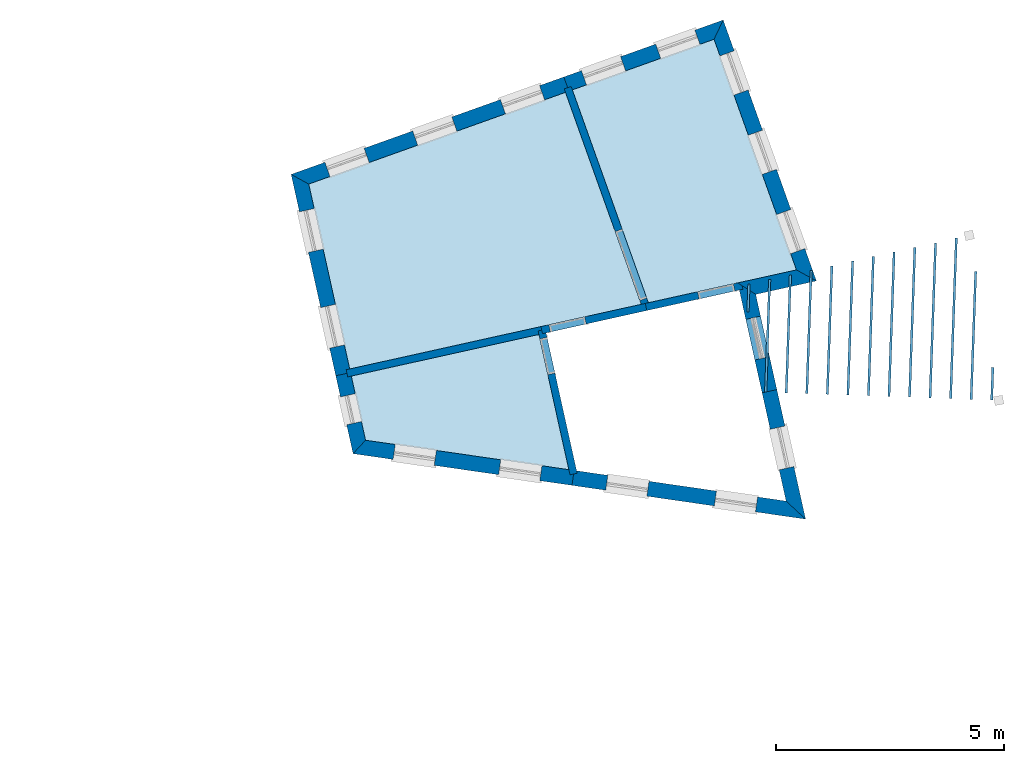
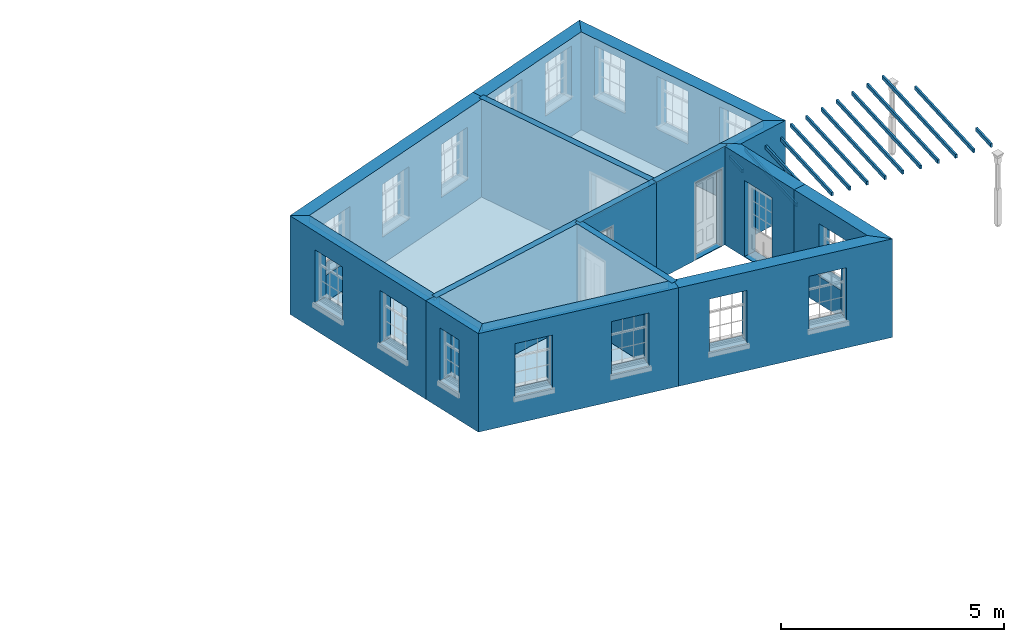
# One storey, part 1 of 11: 19 slabs, 15 walls, 21 openings.
"""IFC2X3 building model written with IfcOpenShell, lengths in metres."""

from ifc_helpers import new_model, si_unit, frame, origin, place, context, subcontext, project, spatial, polyline, outline, extrude, material, layer, layer_set, layer_usage, element, save


model = new_model("IFC2X3")

# Units and contexts
model_context = context("Model", 3, world=origin())
body_context = subcontext(model_context, "Body", "Model", "MODEL_VIEW")
ifc_project = project(units=[si_unit("PLANEANGLEUNIT", "RADIAN"), si_unit("MASSUNIT", "GRAM", prefix="KILO"), si_unit("FORCEUNIT", "NEWTON", prefix="KILO"), si_unit("LENGTHUNIT", "METRE")], contexts=[model_context])

# Site, building, storey
site_placement = place(None, origin())
site = spatial("IfcSite", under=ifc_project, at=site_placement, CompositionType="ELEMENT")
building_placement = place(None, origin())
building = spatial("IfcBuilding", under=site, at=building_placement, Name="Building plot-16", CompositionType="ELEMENT")
storey_placement = place(None, frame((0.0, 0.0, 9.0)))
storey = spatial("IfcBuildingStorey", under=building, at=storey_placement, Name="Floor 2", CompositionType="ELEMENT", Elevation=9.0)

# Slabs
slab_1_placement = place(storey_placement, frame((0.0, 0.0, 2.5)))
element("IfcSlab", 1, at=slab_1_placement, inside=storey, Name="Slab", ObjectType="Slab", PredefinedType="FLOOR", context=body_context, shape_type="SweptSolid", body=[
    extrude(outline(polyline([(91.7432052171659, 34.3882184194522), (87.637101511753, 33.4776402546096), (87.9484434240576, 32.0736946856034), (92.3993213504913, 31.4295697385958), (91.7432052171659, 34.3882184194522)])), origin(), (0.0, 0.0, 1.0), 0.2),
])
slab_2_placement = place(storey_placement, frame((0.0, 0.0, 2.5)))
element("IfcSlab", 2, at=slab_2_placement, inside=storey, Name="Slab", ObjectType="Slab", PredefinedType="FLOOR", context=body_context, shape_type="SweptSolid", body=[
    extrude(outline(polyline([(87.6024611335815, 33.6338453896089), (93.9830197157487, 35.0488114355862), (92.3250201117694, 39.6884235569242), (86.7051504212186, 37.6801216821844), (87.6024611335815, 33.6338453896089)])), origin(), (0.0, 0.0, 1.0), 0.2),
])
slab_3_placement = place(storey_placement, frame((0.0, 0.0, 2.5)))
element("IfcSlab", 3, at=slab_3_placement, inside=storey, Name="Slab", ObjectType="Slab", PredefinedType="FLOOR", context=body_context, shape_type="SweptSolid", body=[
    extrude(outline(polyline([(94.1404528776861, 35.0837241435856), (97.3810072176828, 35.8023562668068), (95.5770005534573, 40.8505427478087), (92.4756885775016, 39.7422660441802), (94.1404528776861, 35.0837241435856)])), origin(), (0.0, 0.0, 1.0), 0.2),
])
slab_4_placement = place(storey_placement, frame((0.0, 0.0, 2.2)))
element("IfcSlab", 4, at=slab_4_placement, inside=storey, Name="Slab", ObjectType="Slab", PredefinedType="FLOOR", context=body_context, shape_type="SweptSolid", body=[
    extrude(outline(polyline([(96.2945786334011, 34.8786023730829), (96.3445470186293, 34.8768245998461), (96.3663257403099, 35.488965412949), (96.3163573550816, 35.4907431861859), (96.2945786334011, 34.8786023730829)])), origin(), (0.0, 0.0, 1.0), 0.1),
])
slab_5_placement = place(storey_placement, frame((0.0, 0.0, 2.2)))
element("IfcSlab", 5, at=slab_5_placement, inside=storey, Name="Slab", ObjectType="Slab", PredefinedType="FLOOR", context=body_context, shape_type="SweptSolid", body=[
    extrude(outline(polyline([(96.6826102640248, 33.128837028559), (96.732578649253, 33.1270592553222), (96.8201913819808, 35.5896156090296), (96.7702229967525, 35.5913933822664), (96.6826102640248, 33.128837028559)])), origin(), (0.0, 0.0, 1.0), 0.1),
])
slab_6_placement = place(storey_placement, frame((0.0, 0.0, 2.2)))
element("IfcSlab", 6, at=slab_6_placement, inside=storey, Name="Slab", ObjectType="Slab", PredefinedType="FLOOR", context=body_context, shape_type="SweptSolid", body=[
    extrude(outline(polyline([(97.132325731079, 33.1128370694275), (97.1822941163072, 33.1110592961907), (97.2740570236516, 35.6902658051106), (97.2240886384234, 35.6920435783474), (97.132325731079, 33.1128370694275)])), origin(), (0.0, 0.0, 1.0), 0.1),
])
slab_7_placement = place(storey_placement, frame((0.0, 0.0, 2.2)))
element("IfcSlab", 7, at=slab_7_placement, inside=storey, Name="Slab", ObjectType="Slab", PredefinedType="FLOOR", context=body_context, shape_type="SweptSolid", body=[
    extrude(outline(polyline([(97.5820411981332, 33.096837110296), (97.6320095833615, 33.0950593370592), (97.7279226653225, 35.7909160011912), (97.6779542800943, 35.792693774428), (97.5820411981332, 33.096837110296)])), origin(), (0.0, 0.0, 1.0), 0.1),
])
slab_8_placement = place(storey_placement, frame((0.0, 0.0, 2.2)))
element("IfcSlab", 8, at=slab_8_placement, inside=storey, Name="Slab", ObjectType="Slab", PredefinedType="FLOOR", context=body_context, shape_type="SweptSolid", body=[
    extrude(outline(polyline([(98.0317566651874, 33.0808371511646), (98.0817250504157, 33.0790593779277), (98.1817883069934, 35.8915661972717), (98.1318199217651, 35.8933439705085), (98.0317566651874, 33.0808371511646)])), origin(), (0.0, 0.0, 1.0), 0.1),
])
slab_9_placement = place(storey_placement, frame((0.0, 0.0, 2.2)))
element("IfcSlab", 9, at=slab_9_placement, inside=storey, Name="Slab", ObjectType="Slab", PredefinedType="FLOOR", context=body_context, shape_type="SweptSolid", body=[
    extrude(outline(polyline([(98.4814721322416, 33.0648371920326), (98.5314405174699, 33.0630594187958), (98.6356539486643, 35.9922163933527), (98.585685563436, 35.9939941665896), (98.4814721322416, 33.0648371920326)])), origin(), (0.0, 0.0, 1.0), 0.1),
])
slab_10_placement = place(storey_placement, frame((0.0, 0.0, 2.2)))
element("IfcSlab", 10, at=slab_10_placement, inside=storey, Name="Slab", ObjectType="Slab", PredefinedType="FLOOR", context=body_context, shape_type="SweptSolid", body=[
    extrude(outline(polyline([(98.9311875992958, 33.0488372329012), (98.9811559845241, 33.0470594596643), (99.0895195903352, 36.0928665894337), (99.0395512051069, 36.0946443626706), (98.9311875992958, 33.0488372329012)])), origin(), (0.0, 0.0, 1.0), 0.1),
])
slab_11_placement = place(storey_placement, frame((0.0, 0.0, 2.2)))
element("IfcSlab", 11, at=slab_11_placement, inside=storey, Name="Slab", ObjectType="Slab", PredefinedType="FLOOR", context=body_context, shape_type="SweptSolid", body=[
    extrude(outline(polyline([(99.38090306635, 33.0328372737697), (99.4308714515783, 33.0310595005328), (99.543385232006, 36.1935167855143), (99.4934168467778, 36.1952945587511), (99.38090306635, 33.0328372737697)])), origin(), (0.0, 0.0, 1.0), 0.1),
])
slab_12_placement = place(storey_placement, frame((0.0, 0.0, 2.2)))
element("IfcSlab", 12, at=slab_12_placement, inside=storey, Name="Slab", ObjectType="Slab", PredefinedType="FLOOR", context=body_context, shape_type="SweptSolid", body=[
    extrude(outline(polyline([(99.8306185334042, 33.0168373146382), (99.8805869186325, 33.0150595414014), (99.9972508736769, 36.2941669815953), (99.9472824884486, 36.2959447548321), (99.8306185334042, 33.0168373146382)])), origin(), (0.0, 0.0, 1.0), 0.1),
])
slab_13_placement = place(storey_placement, frame((0.0, 0.0, 2.2)))
element("IfcSlab", 13, at=slab_13_placement, inside=storey, Name="Slab", ObjectType="Slab", PredefinedType="FLOOR", context=body_context, shape_type="SweptSolid", body=[
    extrude(outline(polyline([(100.280334000458, 33.0008373555063), (100.330302385687, 32.9990595822694), (100.451116515348, 36.3948171776758), (100.40114813012, 36.3965949509127), (100.280334000458, 33.0008373555063)])), origin(), (0.0, 0.0, 1.0), 0.1),
])
slab_14_placement = place(storey_placement, frame((0.0, 0.0, 2.2)))
element("IfcSlab", 14, at=slab_14_placement, inside=storey, Name="Slab", ObjectType="Slab", PredefinedType="FLOOR", context=body_context, shape_type="SweptSolid", body=[
    extrude(outline(polyline([(100.730049467513, 32.9848373963748), (100.780017852741, 32.983059623138), (100.904982157019, 36.4954673737568), (100.85501377179, 36.4972451469937), (100.730049467513, 32.9848373963748)])), origin(), (0.0, 0.0, 1.0), 0.1),
])
slab_15_placement = place(storey_placement, frame((0.0, 0.0, 2.2)))
element("IfcSlab", 15, at=slab_15_placement, inside=storey, Name="Slab", ObjectType="Slab", PredefinedType="FLOOR", context=body_context, shape_type="SweptSolid", body=[
    extrude(outline(polyline([(101.179764934567, 32.9688374372433), (101.229733319795, 32.9670596640065), (101.329344845758, 35.7668695606528), (101.27937646053, 35.7686473338897), (101.179764934567, 32.9688374372433)])), origin(), (0.0, 0.0, 1.0), 0.1),
])
slab_16_placement = place(storey_placement, frame((0.0, 0.0, 2.2)))
element("IfcSlab", 16, at=slab_16_placement, inside=storey, Name="Slab", ObjectType="Slab", PredefinedType="FLOOR", context=body_context, shape_type="SweptSolid", body=[
    extrude(outline(polyline([(101.629480401621, 32.9528374781114), (101.679448786849, 32.9510597048745), (101.705021440101, 33.6698376471343), (101.655053054873, 33.6716154203711), (101.629480401621, 32.9528374781114)])), origin(), (0.0, 0.0, 1.0), 0.1),
])
slab_17_placement = place(storey_placement, origin())
element("IfcSlab", 17, at=slab_17_placement, inside=storey, Name="Slab", ObjectType="Slab", PredefinedType="FLOOR", context=body_context, shape_type="SweptSolid", body=[
    extrude(outline(polyline([(91.7432052171659, 34.3882184194522), (87.637101511753, 33.4776402546096), (87.9484434240576, 32.0736946856034), (92.3993213504913, 31.4295697385958), (91.7432052171659, 34.3882184194522)])), origin(), (0.0, 0.0, 1.0), 0.02),
])
slab_18_placement = place(storey_placement, origin())
element("IfcSlab", 18, at=slab_18_placement, inside=storey, Name="Slab", ObjectType="Slab", PredefinedType="FLOOR", context=body_context, shape_type="SweptSolid", body=[
    extrude(outline(polyline([(87.6024611335815, 33.6338453896089), (93.9830197157487, 35.0488114355862), (92.3250201117694, 39.6884235569242), (86.7051504212186, 37.6801216821844), (87.6024611335815, 33.6338453896089)])), origin(), (0.0, 0.0, 1.0), 0.02),
])
slab_19_placement = place(storey_placement, origin())
element("IfcSlab", 19, at=slab_19_placement, inside=storey, Name="Slab", ObjectType="Slab", PredefinedType="FLOOR", context=body_context, shape_type="SweptSolid", body=[
    extrude(outline(polyline([(94.1404528776861, 35.0837241435856), (97.3810072176828, 35.8023562668068), (95.5770005534573, 40.8505427478087), (92.4756885775016, 39.7422660441802), (94.1404528776861, 35.0837241435856)])), origin(), (0.0, 0.0, 1.0), 0.02),
])

# Wall, opening
ifc_material_1 = material(Name="Masonry")
ifc_layer_1 = layer(ifc_material_1, 0.33, ventilated=False)
ifc_layer_set_1 = layer_set([ifc_layer_1], Name="My Wall")
ifc_layer_usage_1 = layer_usage(ifc_layer_set_1, "AXIS2", "NEGATIVE", 0.08)
wall_1_placement = place(storey_placement, origin())
wall_1 = element("IfcWallStandardCase", 20, at=wall_1_placement, inside=storey, material=ifc_layer_usage_1, Name="exterior", context=body_context, shape_type="SweptSolid", body=[
    extrude(outline(polyline([(97.1549084446968, 30.7413476988825), (97.5805288405461, 30.3463147311604), (96.9516649800753, 33.1820737328336), (96.6294918891393, 33.110627952855), (97.1549084446968, 30.7413476988825)])), origin(), (0.0, 0.0, 1.0), 2.7),
])
opening_1_placement = place(storey_placement, frame((0.0, 0.0, 0.75)))
element("IfcOpeningElement", 21, at=opening_1_placement, cuts=wall_1, Name="Opening", ObjectType="Opening", context=body_context, shape_type="SweptSolid", body=[
    extrude(outline(polyline([(97.3254209005413, 31.496682374684), (97.1284037496912, 32.3850990799923), (96.8062306587552, 32.3136533000138), (97.0032478096053, 31.4252365947054), (97.3254209005413, 31.496682374684)])), origin(), (0.0, 0.0, 1.0), 1.445),
])

wall_2_placement = place(storey_placement, origin())
wall_2 = element("IfcWallStandardCase", 22, at=wall_2_placement, inside=storey, material=ifc_layer_usage_1, Name="exterior", context=body_context, shape_type="SweptSolid", body=[
    extrude(outline(polyline([(96.6294918891393, 33.110627952855), (96.9516649800753, 33.1820737328336), (96.4893931799692, 35.2666130119531), (96.0957743090546, 35.5173403229106), (96.6294918891393, 33.110627952855)])), origin(), (0.0, 0.0, 1.0), 2.7),
])
opening_2_placement = place(storey_placement, frame((0.0, 0.0, 0.0199999999999996)))
element("IfcOpeningElement", 23, at=opening_2_placement, cuts=wall_2, Name="Opening", ObjectType="Opening", context=body_context, shape_type="SweptSolid", body=[
    extrude(outline(polyline([(96.7919748600008, 33.9021702814574), (96.5949577091508, 34.7905869867657), (96.2727846182148, 34.7191412067871), (96.4698017690648, 33.8307245014788), (96.7919748600008, 33.9021702814574)])), origin(), (0.0, 0.0, 1.0), 2.08),
])

# Wall
wall_3_placement = place(storey_placement, origin())
element("IfcWallStandardCase", 24, at=wall_3_placement, inside=storey, material=ifc_layer_usage_1, Name="exterior", context=body_context, shape_type="SweptSolid", body=[
    extrude(outline(polyline([(96.0957743090546, 35.5173403229106), (96.4893931799692, 35.2666130119531), (97.8176362791509, 35.5611669858636), (97.3810072176828, 35.8023562668068), (96.0957743090546, 35.5173403229106)])), origin(), (0.0, 0.0, 1.0), 2.7),
])

# Wall, openings
wall_4_placement = place(storey_placement, origin())
wall_4 = element("IfcWallStandardCase", 25, at=wall_4_placement, inside=storey, material=ifc_layer_usage_1, Name="exterior", context=body_context, shape_type="SweptSolid", body=[
    extrude(outline(polyline([(97.3810072176828, 35.8023562668068), (97.8176362791509, 35.5611669858636), (95.7767041340643, 41.2723465883469), (95.5770005534573, 40.8505427478087), (97.3810072176828, 35.8023562668068)])), origin(), (0.0, 0.0, 1.0), 2.7),
])
opening_3_placement = place(storey_placement, frame((0.0, 0.0, 1.05)))
element("IfcOpeningElement", 26, at=opening_3_placement, cuts=wall_4, Name="Opening", ObjectType="Opening", context=body_context, shape_type="SweptSolid", body=[
    extrude(outline(polyline([(97.5651502138981, 36.2677035893733), (97.2589210676294, 37.1246304882249), (96.9481673570568, 37.0135803582594), (97.2543965033255, 36.1566534594077), (97.5651502138981, 36.2677035893733)])), origin(), (0.0, 0.0, 1.0), 1.445),
])
opening_4_placement = place(storey_placement, frame((0.0, 0.0, 1.05)))
element("IfcOpeningElement", 27, at=opening_4_placement, cuts=wall_4, Name="Opening", ObjectType="Opening", context=body_context, shape_type="SweptSolid", body=[
    extrude(outline(polyline([(96.9446691657534, 38.0040076181098), (96.6384400194846, 38.8609345169614), (96.3276863089121, 38.7498843869959), (96.6339154551808, 37.8929574881442), (96.9446691657534, 38.0040076181098)])), origin(), (0.0, 0.0, 1.0), 1.445),
])
opening_5_placement = place(storey_placement, frame((0.0, 0.0, 1.05)))
element("IfcOpeningElement", 28, at=opening_5_placement, cuts=wall_4, Name="Opening", ObjectType="Opening", context=body_context, shape_type="SweptSolid", body=[
    extrude(outline(polyline([(96.3241881176086, 39.7403116468463), (96.0179589713399, 40.5972385456979), (95.7072052607673, 40.4861884157324), (96.013434407036, 39.6292615168807), (96.3241881176086, 39.7403116468463)])), origin(), (0.0, 0.0, 1.0), 1.445),
])

wall_5_placement = place(storey_placement, origin())
wall_5 = element("IfcWallStandardCase", 29, at=wall_5_placement, inside=storey, material=ifc_layer_usage_1, Name="exterior", context=body_context, shape_type="SweptSolid", body=[
    extrude(outline(polyline([(95.5770005534573, 40.8505427478087), (95.7767041340643, 41.2723465883469), (92.2893042146699, 40.0260985111248), (92.4003543446355, 39.7153448005522), (95.5770005534573, 40.8505427478087)])), origin(), (0.0, 0.0, 1.0), 2.7),
])
opening_6_placement = place(storey_placement, frame((0.0, 0.0, 1.05)))
element("IfcOpeningElement", 30, at=opening_6_placement, cuts=wall_5, Name="Opening", ObjectType="Opening", context=body_context, shape_type="SweptSolid", body=[
    extrude(outline(polyline([(95.1567529953617, 41.0508024774225), (94.29982609651, 40.7445733311538), (94.4108762264756, 40.4338196205812), (95.2678031253273, 40.74004876685), (95.1567529953617, 41.0508024774225)])), origin(), (0.0, 0.0, 1.0), 1.445),
])
opening_7_placement = place(storey_placement, frame((0.0, 0.0, 1.05)))
element("IfcOpeningElement", 31, at=opening_7_placement, cuts=wall_5, Name="Opening", ObjectType="Opening", context=body_context, shape_type="SweptSolid", body=[
    extrude(outline(polyline([(93.5307627745177, 40.4697428819803), (92.6738358756661, 40.1635137357116), (92.7848860056317, 39.852760025139), (93.6418129044833, 40.1589891714077), (93.5307627745177, 40.4697428819803)])), origin(), (0.0, 0.0, 1.0), 1.445),
])

wall_6_placement = place(storey_placement, origin())
wall_6 = element("IfcWallStandardCase", 32, at=wall_6_placement, inside=storey, material=ifc_layer_usage_1, Name="exterior", context=body_context, shape_type="SweptSolid", body=[
    extrude(outline(polyline([(92.4003543446355, 39.7153448005522), (92.2893042146699, 40.0260985111248), (86.3199462197779, 37.892904413708), (86.7051504212186, 37.6801216821844), (92.4003543446355, 39.7153448005522)])), origin(), (0.0, 0.0, 1.0), 2.7),
])
opening_8_placement = place(storey_placement, frame((0.0, 0.0, 0.75)))
element("IfcOpeningElement", 33, at=opening_8_placement, cuts=wall_6, Name="Opening", ObjectType="Opening", context=body_context, shape_type="SweptSolid", body=[
    extrude(outline(polyline([(91.7574900780122, 39.8360508078019), (90.9005631791605, 39.5298216615332), (91.0116133091261, 39.2190679509606), (91.8685402079777, 39.5252970972293), (91.7574900780122, 39.8360508078019)])), origin(), (0.0, 0.0, 1.0), 1.445),
])
opening_9_placement = place(storey_placement, frame((0.0, 0.0, 0.75)))
element("IfcOpeningElement", 34, at=opening_9_placement, cuts=wall_6, Name="Opening", ObjectType="Opening", context=body_context, shape_type="SweptSolid", body=[
    extrude(outline(polyline([(89.8369349058449, 39.1497262548875), (88.9800080069932, 38.8434971086188), (89.0910581369588, 38.5327433980462), (89.9479850358105, 38.8389725443149), (89.8369349058449, 39.1497262548875)])), origin(), (0.0, 0.0, 1.0), 1.445),
])
opening_10_placement = place(storey_placement, frame((0.0, 0.0, 0.75)))
element("IfcOpeningElement", 35, at=opening_10_placement, cuts=wall_6, Name="Opening", ObjectType="Opening", context=body_context, shape_type="SweptSolid", body=[
    extrude(outline(polyline([(87.9163797336776, 38.4634017019731), (87.0594528348259, 38.1571725557044), (87.1705029647915, 37.8464188451318), (88.0274298636432, 38.1526479914005), (87.9163797336776, 38.4634017019731)])), origin(), (0.0, 0.0, 1.0), 1.445),
])

wall_7_placement = place(storey_placement, origin())
wall_7 = element("IfcWallStandardCase", 36, at=wall_7_placement, inside=storey, material=ifc_layer_usage_1, Name="exterior", context=body_context, shape_type="SweptSolid", body=[
    extrude(outline(polyline([(86.7051504212186, 37.6801216821844), (86.3199462197779, 37.892904413708), (87.2976082317312, 33.4842970421306), (87.6197813226672, 33.5557428221092), (86.7051504212186, 37.6801216821844)])), origin(), (0.0, 0.0, 1.0), 2.7),
])
opening_11_placement = place(storey_placement, frame((0.0, 0.0, 0.75)))
element("IfcOpeningElement", 37, at=opening_11_placement, cuts=wall_7, Name="Opening", ObjectType="Opening", context=body_context, shape_type="SweptSolid", body=[
    extrude(outline(polyline([(86.5016662783098, 37.0734674510234), (86.6986834291598, 36.1850507457151), (87.0208565200958, 36.2564965256937), (86.8238393692458, 37.144913231002), (86.5016662783098, 37.0734674510234)])), origin(), (0.0, 0.0, 1.0), 1.445),
])
opening_12_placement = place(storey_placement, frame((0.0, 0.0, 0.75)))
element("IfcOpeningElement", 38, at=opening_12_placement, cuts=wall_7, Name="Opening", ObjectType="Opening", context=body_context, shape_type="SweptSolid", body=[
    extrude(outline(polyline([(86.9666218636407, 34.9768260801977), (87.1636390144908, 34.0884093748893), (87.4858121054268, 34.1598551548679), (87.2887949545767, 35.0482718601763), (86.9666218636407, 34.9768260801977)])), origin(), (0.0, 0.0, 1.0), 1.445),
])

# Wall, opening
wall_8_placement = place(storey_placement, origin())
wall_8 = element("IfcWallStandardCase", 39, at=wall_8_placement, inside=storey, material=ifc_layer_usage_1, Name="exterior", context=body_context, shape_type="SweptSolid", body=[
    extrude(outline(polyline([(87.6197813226672, 33.5557428221092), (87.2976082317312, 33.4842970421306), (87.6756142911979, 31.7797403754188), (87.9484434240576, 32.0736946856034), (87.6197813226672, 33.5557428221092)])), origin(), (0.0, 0.0, 1.0), 2.7),
])
opening_13_placement = place(storey_placement, frame((0.0, 0.0, 0.75)))
element("IfcOpeningElement", 40, at=opening_13_placement, cuts=wall_8, Name="Opening", ObjectType="Opening", context=body_context, shape_type="SweptSolid", body=[
    extrude(outline(polyline([(87.4002633796378, 33.0213903972391), (87.5355773568699, 32.4112140886482), (87.8577504478059, 32.4826598686268), (87.7224364705738, 33.0928361772177), (87.4002633796378, 33.0213903972391)])), origin(), (0.0, 0.0, 1.0), 1.445),
])

# Wall, openings
wall_9_placement = place(storey_placement, origin())
wall_9 = element("IfcWallStandardCase", 41, at=wall_9_placement, inside=storey, material=ifc_layer_usage_1, Name="exterior", context=body_context, shape_type="SweptSolid", body=[
    extrude(outline(polyline([(87.9484434240576, 32.0736946856034), (87.6756142911979, 31.7797403754188), (92.4666954104416, 31.086381689099), (92.513960177979, 31.4129793647637), (87.9484434240576, 32.0736946856034)])), origin(), (0.0, 0.0, 1.0), 2.7),
])
opening_14_placement = place(storey_placement, frame((0.0, 0.0, 0.75)))
element("IfcOpeningElement", 42, at=opening_14_placement, cuts=wall_9, Name="Opening", ObjectType="Opening", context=body_context, shape_type="SweptSolid", body=[
    extrude(outline(polyline([(88.5512372257678, 31.653021425663), (89.4518550586615, 31.5226852485144), (89.4991198261989, 31.8492829241791), (88.5985019933052, 31.9796191013278), (88.5512372257678, 31.653021425663)])), origin(), (0.0, 0.0, 1.0), 1.445),
])
opening_15_placement = place(storey_placement, frame((0.0, 0.0, 0.75)))
element("IfcOpeningElement", 43, at=opening_15_placement, cuts=wall_9, Name="Opening", ObjectType="Opening", context=body_context, shape_type="SweptSolid", body=[
    extrude(outline(polyline([(90.861336737919, 31.3187069936699), (91.7619545708128, 31.1883708165212), (91.8092193383502, 31.514968492186), (90.9086015054565, 31.6453046693347), (90.861336737919, 31.3187069936699)])), origin(), (0.0, 0.0, 1.0), 1.445),
])

wall_10_placement = place(storey_placement, origin())
wall_10 = element("IfcWallStandardCase", 44, at=wall_10_placement, inside=storey, material=ifc_layer_usage_1, Name="exterior", context=body_context, shape_type="SweptSolid", body=[
    extrude(outline(polyline([(92.513960177979, 31.4129793647637), (92.4666954104416, 31.086381689099), (97.5805288405461, 30.3463147311604), (97.1549084446968, 30.7413476988825), (92.513960177979, 31.4129793647637)])), origin(), (0.0, 0.0, 1.0), 2.7),
])
opening_16_placement = place(storey_placement, frame((0.0, 0.0, 0.75)))
element("IfcOpeningElement", 45, at=opening_16_placement, cuts=wall_10, Name="Opening", ObjectType="Opening", context=body_context, shape_type="SweptSolid", body=[
    extrude(outline(polyline([(93.2052832675461, 30.979494267745), (94.1059011004399, 30.8491580905963), (94.1531658679773, 31.1757557662611), (93.2525480350835, 31.3060919434098), (93.2052832675461, 30.979494267745)])), origin(), (0.0, 0.0, 1.0), 1.445),
])
opening_17_placement = place(storey_placement, frame((0.0, 0.0, 0.75)))
element("IfcOpeningElement", 46, at=opening_17_placement, cuts=wall_10, Name="Opening", ObjectType="Opening", context=body_context, shape_type="SweptSolid", body=[
    extrude(outline(polyline([(95.5830768146488, 30.6353832478883), (96.4836946475426, 30.5050470707397), (96.53095941508, 30.8316447464044), (95.6303415821863, 30.9619809235531), (95.5830768146488, 30.6353832478883)])), origin(), (0.0, 0.0, 1.0), 1.445),
])

# Wall, opening
ifc_material_2 = material(Name="Masonry")
ifc_layer_2 = layer(ifc_material_2, 0.16, ventilated=False)
ifc_layer_set_2 = layer_set([ifc_layer_2], Name="My Wall")
ifc_layer_usage_2 = layer_usage(ifc_layer_set_2, "AXIS2", "NEGATIVE", 0.08)
wall_11_placement = place(storey_placement, origin())
wall_11 = element("IfcWallStandardCase", 47, at=wall_11_placement, inside=storey, material=ifc_layer_usage_2, Name="interior", context=body_context, shape_type="SweptSolid", body=[
    extrude(outline(polyline([(92.4243994850158, 31.3164839815775), (92.580604620015, 31.3511243597489), (91.8820901630794, 34.5009613651233), (91.7258850280802, 34.4663209869519), (92.4243994850158, 31.3164839815775)])), origin(), (0.0, 0.0, 1.0), 2.7),
])
opening_18_placement = place(storey_placement, frame((0.0, 0.0, 0.0199999999999996)))
element("IfcOpeningElement", 48, at=opening_18_placement, cuts=wall_11, Name="Opening", ObjectType="Opening", context=body_context, shape_type="SweptSolid", body=[
    extrude(outline(polyline([(92.0942624793795, 33.5442049132528), (91.9210605885223, 34.3252305882491), (91.764855453523, 34.2905902100777), (91.9380573443802, 33.5095645350814), (92.0942624793795, 33.5442049132528)])), origin(), (0.0, 0.0, 1.0), 2.1),
])

# Wall
wall_12_placement = place(storey_placement, origin())
element("IfcWallStandardCase", 49, at=wall_12_placement, inside=storey, material=ifc_layer_usage_2, Name="interior", context=body_context, shape_type="SweptSolid", body=[
    extrude(outline(polyline([(91.8213077846655, 34.405538608538), (91.7866674064941, 34.5617437435372), (87.5243585660819, 33.6165252005231), (87.5589989442533, 33.4603200655239), (91.8213077846655, 34.405538608538)])), origin(), (0.0, 0.0, 1.0), 2.7),
])

# Wall, opening
wall_13_placement = place(storey_placement, origin())
wall_13 = element("IfcWallStandardCase", 50, at=wall_13_placement, inside=storey, material=ifc_layer_usage_2, Name="interior", context=body_context, shape_type="SweptSolid", body=[
    extrude(outline(polyline([(94.0715489961098, 35.0684438743723), (94.1061893742812, 34.9122387393731), (96.2085172547257, 35.378455376997), (96.1738768765543, 35.5346605119962), (94.0715489961098, 35.0684438743723)])), origin(), (0.0, 0.0, 1.0), 2.7),
])
opening_19_placement = place(storey_placement, frame((0.0, 0.0, 0.0199999999999996)))
element("IfcOpeningElement", 51, at=opening_19_placement, cuts=wall_13, Name="Opening", ObjectType="Opening", context=body_context, shape_type="SweptSolid", body=[
    extrude(outline(polyline([(95.2517608028552, 35.1662830606969), (96.0327864778515, 35.3394849515541), (95.9981460996801, 35.4956900865534), (95.2171204246837, 35.3224881956962), (95.2517608028552, 35.1662830606969)])), origin(), (0.0, 0.0, 1.0), 2.1),
])

wall_14_placement = place(storey_placement, origin())
wall_14 = element("IfcWallStandardCase", 52, at=wall_14_placement, inside=storey, material=ifc_layer_usage_2, Name="interior", context=body_context, shape_type="SweptSolid", body=[
    extrude(outline(polyline([(94.0135349523294, 34.9634200632447), (94.1642034180616, 35.0172625505007), (92.4487673338736, 39.8176002770463), (92.2980988681414, 39.7637577897903), (94.0135349523294, 34.9634200632447)])), origin(), (0.0, 0.0, 1.0), 2.7),
])
opening_20_placement = place(storey_placement, frame((0.0, 0.0, 0.0199999999999996)))
element("IfcOpeningElement", 53, at=opening_20_placement, cuts=wall_14, Name="Opening", ObjectType="Opening", context=body_context, shape_type="SweptSolid", body=[
    extrude(outline(polyline([(94.1036306198986, 35.1867645744494), (93.5652057473382, 36.693449231771), (93.414537281606, 36.639606744515), (93.9529621541664, 35.1329220871934), (94.1036306198986, 35.1867645744494)])), origin(), (0.0, 0.0, 1.0), 2.1),
])

wall_15_placement = place(storey_placement, origin())
wall_15 = element("IfcWallStandardCase", 54, at=wall_15_placement, inside=storey, material=ifc_layer_usage_2, Name="interior", context=body_context, shape_type="SweptSolid", body=[
    extrude(outline(polyline([(91.7866674064941, 34.5617437435372), (91.8213077846655, 34.405538608538), (94.1061893742812, 34.9122387393731), (94.0715489961098, 35.0684438743723), (91.7866674064941, 34.5617437435372)])), origin(), (0.0, 0.0, 1.0), 2.7),
])
opening_21_placement = place(storey_placement, frame((0.0, 0.0, 0.0199999999999996)))
element("IfcOpeningElement", 55, at=opening_21_placement, cuts=wall_15, Name="Opening", ObjectType="Opening", context=body_context, shape_type="SweptSolid", body=[
    extrude(outline(polyline([(91.9970385615397, 34.4445090339808), (92.778064236536, 34.617710924838), (92.7434238583646, 34.7739160598373), (91.9623981833683, 34.6007141689801), (91.9970385615397, 34.4445090339808)])), origin(), (0.0, 0.0, 1.0), 2.1),
])

save(model, "model.ifc")
